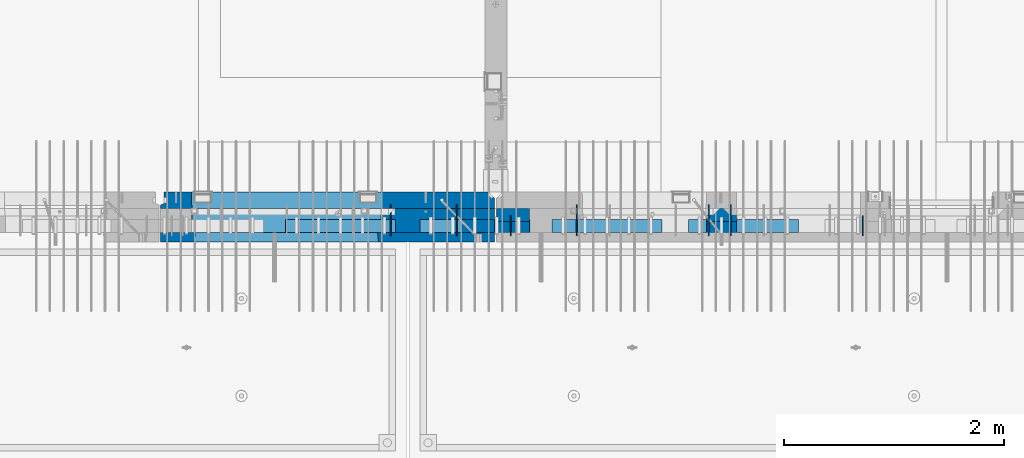
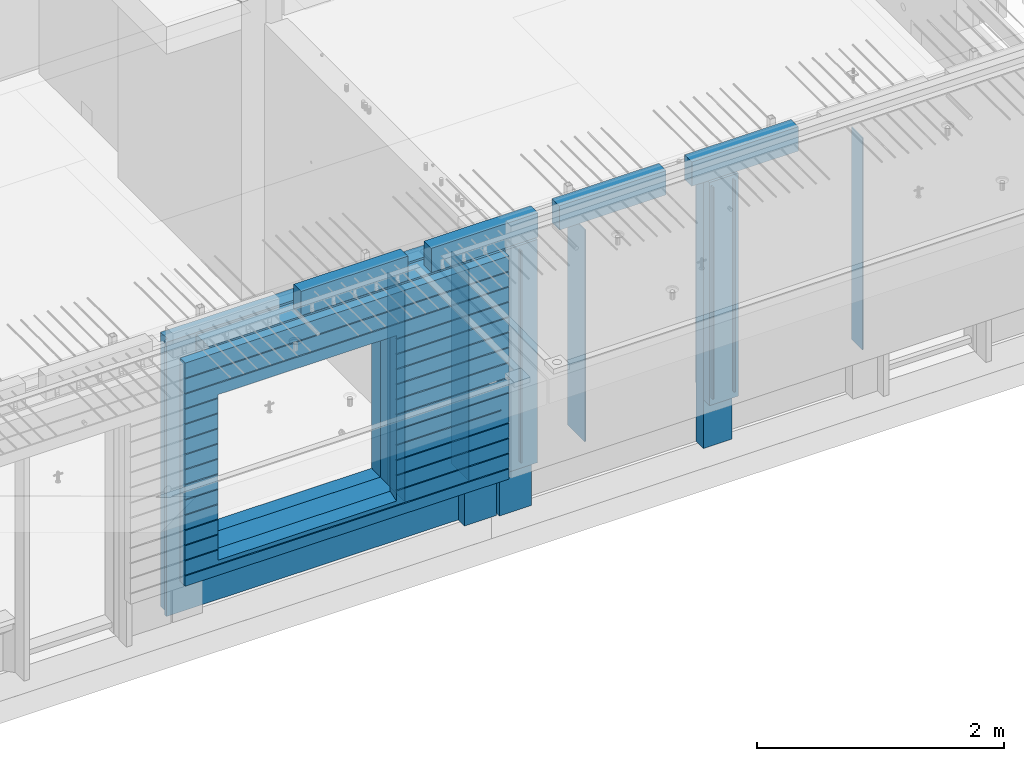
# One storey, part 212 of 325: 20 walls, 8 elements without a shape of their own.
"""IFC2X3 building model written with IfcOpenShell, lengths in millimetres."""

from ifc_helpers import new_model, si_unit, frame, origin_with_axes, place, context, subcontext, project, spatial, faceted_brep, material, type_object, element, aggregate, save


model = new_model("IFC2X3")

# Units and contexts
model_context = context("Model", 3, precision=1e-05, world=origin_with_axes())
body_context = subcontext(model_context, "Body", "Model", "MODEL_VIEW")
ifc_project = project(units=[si_unit("LENGTHUNIT", "METRE", prefix="MILLI"), si_unit("AREAUNIT", "SQUARE_METRE"), si_unit("VOLUMEUNIT", "CUBIC_METRE"), si_unit("MASSUNIT", "GRAM", prefix="KILO"), si_unit("TIMEUNIT", "SECOND"), si_unit("PLANEANGLEUNIT", "RADIAN"), si_unit("SOLIDANGLEUNIT", "STERADIAN"), si_unit("THERMODYNAMICTEMPERATUREUNIT", "DEGREE_CELSIUS"), si_unit("LUMINOUSINTENSITYUNIT", "LUMEN")], contexts=[model_context])

# Site, building, storey
site_placement = place(None, origin_with_axes())
site = spatial("IfcSite", under=ifc_project, at=site_placement, CompositionType="ELEMENT")
building_placement = place(site_placement, origin_with_axes())
building = spatial("IfcBuilding", under=site, at=building_placement, CompositionType="ELEMENT")
storey_placement = place(building_placement, origin_with_axes())
storey = spatial("IfcBuildingStorey", under=building, at=storey_placement, Name="1", CompositionType="ELEMENT", Elevation=0.0)

# Assemblies, wall
assembly_1_placement = place(storey_placement, origin_with_axes())
assembly_1 = element("IfcElementAssembly", 1, at=assembly_1_placement, inside=storey, AssemblyPlace="NOTDEFINED", PredefinedType="REINFORCEMENT_UNIT")
assembly_2_placement = place(assembly_1_placement, origin_with_axes())
assembly_2 = element("IfcElementAssembly", 2, at=assembly_2_placement, Name="Steel Assembly", AssemblyPlace="NOTDEFINED", PredefinedType="NOTDEFINED")
aggregate(assembly_1, [assembly_2])
ifc_material_1 = material()
wall_type_1 = type_object("IfcWallType", PredefinedType="NOTDEFINED")
wall_1_placement = place(assembly_2_placement, frame((26699.9998568133, 7690.00021946163, 84590.0), z_axis=(0.0, 0.0, 1.0), x_axis=(1.0, 0.0, 0.0)))
wall_1 = element("IfcWall", 3, at=wall_1_placement, type_object=wall_type_1, material=ifc_material_1, context=body_context, shape_type="Brep", body=[
    faceted_brep([(0.0, 60.0, -120.0), (0.0, 60.0, 120.0), (1000.0, 60.0, 120.0), (1000.0, 60.0, -120.0), (0.0, -60.0, 120.0), (1000.0, -60.0, 120.0), (0.0, -60.0, -120.0), (1000.0, -60.0, -120.0)], [[[0, 1, 2, 3]], [[1, 4, 5, 2]], [[4, 6, 7, 5]], [[6, 0, 3, 7]], [[5, 7, 3, 2]], [[6, 4, 1, 0]]]),
])
aggregate(assembly_2, [wall_1])

# Assemblies, walls
assembly_3_placement = place(storey_placement, origin_with_axes())
assembly_3 = element("IfcElementAssembly", 4, at=assembly_3_placement, inside=storey, AssemblyPlace="NOTDEFINED", PredefinedType="REINFORCEMENT_UNIT")
assembly_4_placement = place(assembly_3_placement, origin_with_axes())
assembly_4 = element("IfcElementAssembly", 5, at=assembly_4_placement, Name="Steel Assembly", AssemblyPlace="NOTDEFINED", PredefinedType="NOTDEFINED")
wall_2_placement = place(assembly_4_placement, frame((30359.9998568133, 7690.00021946163, 84590.0), z_axis=(0.0, 0.0, 1.0), x_axis=(1.0, 0.0, 0.0)))
wall_2 = element("IfcWall", 6, at=wall_2_placement, type_object=wall_type_1, material=ifc_material_1, context=body_context, shape_type="Brep", body=[
    faceted_brep([(0.0, 60.0, -120.0), (0.0, 60.0, 120.0), (1000.0, 60.0, 120.0), (1000.0, 60.0, -120.0), (0.0, -60.0, 120.0), (1000.0, -60.0, 120.0), (0.0, -60.0, -120.0), (1000.0, -60.0, -120.0)], [[[0, 1, 2, 3]], [[1, 4, 5, 2]], [[4, 6, 7, 5]], [[6, 0, 3, 7]], [[5, 7, 3, 2]], [[6, 4, 1, 0]]]),
])
aggregate(assembly_4, [wall_2])
assembly_5_placement = place(assembly_3_placement, origin_with_axes())
assembly_5 = element("IfcElementAssembly", 7, at=assembly_5_placement, Name="Steel Assembly", AssemblyPlace="NOTDEFINED", PredefinedType="NOTDEFINED")
wall_3_placement = place(assembly_5_placement, frame((29119.9998568133, 7690.00021946163, 84590.0), z_axis=(0.0, 0.0, 1.0), x_axis=(1.0, 0.0, 0.0)))
wall_3 = element("IfcWall", 8, at=wall_3_placement, type_object=wall_type_1, material=ifc_material_1, context=body_context, shape_type="Brep", body=[
    faceted_brep([(0.0, 60.0, -120.0), (0.0, 60.0, 120.0), (1000.0, 60.0, 120.0), (1000.0, 60.0, -120.0), (0.0, -60.0, 120.0), (1000.0, -60.0, 120.0), (0.0, -60.0, -120.0), (1000.0, -60.0, -120.0)], [[[0, 1, 2, 3]], [[1, 4, 5, 2]], [[4, 6, 7, 5]], [[6, 0, 3, 7]], [[5, 7, 3, 2]], [[6, 4, 1, 0]]]),
])
aggregate(assembly_5, [wall_3])
assembly_6_placement = place(assembly_3_placement, origin_with_axes())
assembly_6 = element("IfcElementAssembly", 9, at=assembly_6_placement, Name="Steel Assembly", AssemblyPlace="NOTDEFINED", PredefinedType="NOTDEFINED")
aggregate(assembly_3, [assembly_6, assembly_5, assembly_4])
wall_4_placement = place(assembly_6_placement, frame((27919.9998568133, 7690.00021946163, 84590.0), z_axis=(0.0, 0.0, 1.0), x_axis=(1.0, 0.0, 0.0)))
wall_4 = element("IfcWall", 10, at=wall_4_placement, type_object=wall_type_1, material=ifc_material_1, context=body_context, shape_type="Brep", body=[
    faceted_brep([(0.0, 60.0, -120.0), (0.0, 60.0, 120.0), (1000.0, 60.0, 120.0), (1000.0, 60.0, -120.0), (0.0, -60.0, 120.0), (1000.0, -60.0, 120.0), (0.0, -60.0, -120.0), (1000.0, -60.0, -120.0)], [[[0, 1, 2, 3]], [[1, 4, 5, 2]], [[4, 6, 7, 5]], [[6, 0, 3, 7]], [[5, 7, 3, 2]], [[6, 4, 1, 0]]]),
])
aggregate(assembly_6, [wall_4])

# Assembly, walls
assembly_7_placement = place(storey_placement, origin_with_axes())
assembly_7 = element("IfcElementAssembly", 11, at=assembly_7_placement, inside=storey, AssemblyPlace="NOTDEFINED", PredefinedType="REINFORCEMENT_UNIT")
ifc_material_2 = material(Name="CONCRETE/C35/45")
wall_type_2 = type_object("IfcWallType", PredefinedType="NOTDEFINED")
wall_5_placement = place(assembly_7_placement, frame((28600.0, 7925.0, 83112.5), z_axis=(0.0, 0.0, 1.0), x_axis=(-1.0, 3.00000001838171e-08, 0.0)))
wall_5 = element("IfcWall", 12, at=wall_5_placement, type_object=wall_type_2, material=ifc_material_2, context=body_context, shape_type="Brep", body=[
    faceted_brep([(0.0, 75.0, 1357.5), (0.0, 75.0, -1357.5), (0.0, -15.0, -1357.5), (0.0, -15.0, 1357.5), (60.0, -75.0, -1357.5), (3035.00000000003, 75.0, -1357.5), (3035.00000000003, 45.0, -1357.5), (3002.5, 32.0, -1357.5), (3002.5, -75.0, -1357.5), (60.0, -75.0, 1357.5), (3035.00000000003, 45.0, 1357.5), (3035.00000000003, 75.0, 1357.5), (3002.5, -75.0, 1357.5), (3002.5, 32.0, 1357.5), (2755.00051719707, -75.0, -682.5), (1025.00051719707, -75.0, -682.5), (1025.00051719707, -75.0, 952.5), (2755.00051719707, -75.0, 952.5), (2750.94646314301, 75.0, -678.445945945947), (1029.05457125112, 75.0, -678.445945945947), (1029.05457125112, 75.0, 948.445945945947), (2750.94646314301, 75.0, 948.445945945947)], [[[0, 1, 2, 3]], [[4, 2, 1, 5, 6, 7, 8]], [[3, 2, 4, 9]], [[10, 11, 0, 3, 9, 12, 13]], [[5, 11, 10, 6]], [[13, 7, 6, 10]], [[12, 8, 7, 13]], [[9, 4, 8, 12], [14, 15, 16, 17]], [[14, 18, 19, 15]], [[15, 19, 20, 16]], [[1, 0, 11, 5], [18, 21, 20, 19]], [[16, 20, 21, 17]], [[18, 14, 17, 21]]]),
])
ifc_material_3 = material(Name="Undefined")
wall_type_3 = type_object("IfcWallType", PredefinedType="NOTDEFINED")
wall_6_placement = place(assembly_7_placement, frame((28255.0, 7880.0, 83365.0), z_axis=(0.0, 0.0, 1.0), x_axis=(0.0, -1.0, 0.0)))
wall_6 = element("IfcWall", 13, at=wall_6_placement, type_object=wall_type_3, material=ifc_material_3, Name="(PD)", context=body_context, shape_type="Brep", body=[
    faceted_brep([(0.0, 5.0, -1050.0), (0.0, 5.0, 1050.0), (280.0, 5.0, 1050.0), (280.0, 5.0, -1050.0), (0.0, -5.0, 1050.0), (280.0, -5.0, 1050.0), (0.0, -5.0, -1050.0), (280.0, -5.0, -1050.0)], [[[0, 1, 2, 3]], [[1, 4, 5, 2]], [[4, 6, 7, 5]], [[6, 0, 3, 7]], [[5, 7, 3, 2]], [[6, 4, 1, 0]]]),
])

assembly_8_placement = place(storey_placement, origin_with_axes())
assembly_8 = element("IfcElementAssembly", 14, at=assembly_8_placement, inside=storey, AssemblyPlace="NOTDEFINED", PredefinedType="REINFORCEMENT_UNIT")
wall_7_placement = place(assembly_8_placement, frame((31944.9998946285, 7780.0, 83365.0), z_axis=(0.0, 0.0, 1.0), x_axis=(0.0, -1.0, 0.0)))
wall_7 = element("IfcWall", 15, at=wall_7_placement, type_object=wall_type_3, material=ifc_material_3, Name="(PD)", context=body_context, shape_type="Brep", body=[
    faceted_brep([(0.0, 5.0, -1050.0), (0.0, 5.0, 1050.0), (180.0, 5.0, 1050.0), (180.0, 5.0, -1050.0), (0.0, -5.0, 1050.0), (180.0, -5.0, 1050.0), (0.0, -5.0, -1050.0), (180.0, -5.0, -1050.0)], [[[0, 1, 2, 3]], [[1, 4, 5, 2]], [[4, 6, 7, 5]], [[6, 0, 3, 7]], [[5, 7, 3, 2]], [[6, 4, 1, 0]]]),
])
wall_8_placement = place(assembly_8_placement, frame((28745.0021834468, 7780.0, 83365.0), z_axis=(0.0, 0.0, 1.0), x_axis=(0.0, -1.0, 0.0)))
wall_8 = element("IfcWall", 16, at=wall_8_placement, type_object=wall_type_3, material=ifc_material_3, Name="(PD)", context=body_context, shape_type="Brep", body=[
    faceted_brep([(0.0, 5.0, -1050.0), (0.0, 5.0, 1050.0), (180.0, 5.0, 1050.0), (180.0, 5.0, -1050.0), (0.0, -5.0, 1050.0), (180.0, -5.0, 1050.0), (0.0, -5.0, -1050.0), (180.0, -5.0, -1050.0)], [[[0, 1, 2, 3]], [[1, 4, 5, 2]], [[4, 6, 7, 5]], [[6, 0, 3, 7]], [[5, 7, 3, 2]], [[6, 4, 1, 0]]]),
])
wall_9_placement = place(assembly_8_placement, frame((29345.0021834468, 7880.0, 83365.0), z_axis=(0.0, 0.0, 1.0), x_axis=(0.0, -1.0, 0.0)))
wall_9 = element("IfcWall", 17, at=wall_9_placement, type_object=wall_type_3, material=ifc_material_3, Name="(PD)", context=body_context, shape_type="Brep", body=[
    faceted_brep([(0.0, 5.0, -1050.0), (0.0, 5.0, 1050.0), (280.0, 5.0, 1050.0), (280.0, 5.0, -1050.0), (0.0, -5.0, 1050.0), (280.0, -5.0, 1050.0), (0.0, -5.0, -1050.0), (280.0, -5.0, -1050.0)], [[[0, 1, 2, 3]], [[1, 4, 5, 2]], [[4, 6, 7, 5]], [[6, 0, 3, 7]], [[5, 7, 3, 2]], [[6, 4, 1, 0]]]),
])
wall_10_placement = place(assembly_8_placement, frame((30545.0021834468, 7880.0, 83365.0), z_axis=(0.0, 0.0, 1.0), x_axis=(0.0, -1.0, 0.0)))
wall_10 = element("IfcWall", 18, at=wall_10_placement, type_object=wall_type_3, material=ifc_material_3, Name="(PD)", context=body_context, shape_type="Brep", body=[
    faceted_brep([(0.0, 5.0, -1050.0), (0.0, 5.0, 1050.0), (280.0, 5.0, 1050.0), (280.0, 5.0, -1050.0), (0.0, -5.0, 1050.0), (280.0, -5.0, 1050.0), (0.0, -5.0, -1050.0), (280.0, -5.0, -1050.0)], [[[0, 1, 2, 3]], [[1, 4, 5, 2]], [[4, 6, 7, 5]], [[6, 0, 3, 7]], [[5, 7, 3, 2]], [[6, 4, 1, 0]]]),
])
wall_11_placement = place(assembly_8_placement, frame((30745.0021834468, 7880.0, 83365.0), z_axis=(0.0, 0.0, 1.0), x_axis=(0.0, -1.0, 0.0)))
wall_11 = element("IfcWall", 19, at=wall_11_placement, type_object=wall_type_3, material=ifc_material_3, Name="(PD)", context=body_context, shape_type="Brep", body=[
    faceted_brep([(0.0, 5.0, -1050.0), (0.0, 5.0, 1050.0), (280.0, 5.0, 1050.0), (280.0, 5.0, -1050.0), (0.0, -5.0, 1050.0), (280.0, -5.0, 1050.0), (0.0, -5.0, -1050.0), (280.0, -5.0, -1050.0)], [[[0, 1, 2, 3]], [[1, 4, 5, 2]], [[4, 6, 7, 5]], [[6, 0, 3, 7]], [[5, 7, 3, 2]], [[6, 4, 1, 0]]]),
])

# Wall
wall_12_placement = place(assembly_7_placement, frame((27655.0, 7880.0, 83365.0), z_axis=(0.0, 0.0, 1.0), x_axis=(0.0, -1.0, 0.0)))
wall_12 = element("IfcWall", 20, at=wall_12_placement, type_object=wall_type_3, material=ifc_material_3, Name="(PD)", context=body_context, shape_type="Brep", body=[
    faceted_brep([(0.0, 5.0, -1050.0), (0.0, 5.0, 1050.0), (280.0, 5.0, 1050.0), (280.0, 5.0, -1050.0), (0.0, -5.0, 1050.0), (280.0, -5.0, 1050.0), (0.0, -5.0, -1050.0), (280.0, -5.0, -1050.0)], [[[0, 1, 2, 3]], [[1, 4, 5, 2]], [[4, 6, 7, 5]], [[6, 0, 3, 7]], [[5, 7, 3, 2]], [[6, 4, 1, 0]]]),
])

wall_type_4 = type_object("IfcWallType", PredefinedType="NOTDEFINED")
wall_13_placement = place(assembly_7_placement, frame((28600.0000381475, 7800.0, 83112.5), z_axis=(0.0, 0.0, 1.0), x_axis=(-1.0, 3.00000001838171e-08, 0.0)))
wall_13 = element("IfcWall", 21, at=wall_13_placement, type_object=wall_type_4, material=ifc_material_2, context=body_context, shape_type="Brep", body=[
    faceted_brep([(0.0, 50.0, -1357.5), (0.0, 50.0, 1357.5), (300.001908754726, 50.0, 1357.5), (300.001908754726, 50.0, -1357.5), (0.0, -50.0, 1357.5), (300.001908754726, -50.0, 1357.5), (0.0, -50.0, -1357.5), (300.001908754726, -50.0, -1357.5)], [[[0, 1, 2, 3]], [[1, 4, 5, 2]], [[4, 6, 7, 5]], [[6, 0, 3, 7]], [[5, 7, 3, 2]], [[6, 4, 1, 0]]]),
])

ifc_material_4 = material(Name="SPU")
wall_type_5 = type_object("IfcWallType", PredefinedType="NOTDEFINED")
wall_14_placement = place(assembly_7_placement, frame((28600.0000381475, 7690.0, 83102.5), z_axis=(0.0, 0.0, 1.0), x_axis=(-1.0, 3.00000001838171e-08, 0.0)))
wall_14 = element("IfcWall", 22, at=wall_14_placement, type_object=wall_type_5, material=ifc_material_4, context=body_context, shape_type="Brep", body=[
    faceted_brep([(0.0, 60.0, 1347.5), (0.0, -60.0, 1347.5), (300.001908754726, -60.0, 1347.5), (300.001908754726, 60.0, 1347.5), (0.0, -60.0, -862.5), (300.001908754726, -60.0, -862.5), (300.001908754726, 60.0, -862.5), (0.0, 60.0, -862.5)], [[[0, 1, 2, 3]], [[2, 1, 4, 5]], [[3, 2, 5, 6]], [[0, 3, 6, 7]], [[1, 0, 7, 4]], [[6, 5, 4, 7]]]),
])

wall_type_6 = type_object("IfcWallType", PredefinedType="NOTDEFINED")
wall_15_placement = place(assembly_8_placement, frame((30795.0000381475, 7680.0, 83102.5), z_axis=(0.0, 0.0, 1.0), x_axis=(-1.0, 3.00000001838171e-08, 0.0)))
wall_15 = element("IfcWall", 23, at=wall_15_placement, type_object=wall_type_6, material=ifc_material_4, context=body_context, shape_type="Brep", body=[
    faceted_brep([(0.0, 50.0, 1347.5), (0.0, -50.0, 1347.5), (270.001908754726, -50.0, 1347.5), (270.001908754726, 50.0, 1347.5), (0.0, -50.0, -862.5), (270.001908754726, -50.0, -862.5), (270.001908754726, 50.0, -862.5), (0.0, 50.0, -862.5)], [[[0, 1, 2, 3]], [[2, 1, 4, 5]], [[3, 2, 5, 6]], [[0, 3, 6, 7]], [[1, 0, 7, 4]], [[6, 5, 4, 7]]]),
])

wall_16_placement = place(assembly_8_placement, frame((28915.0000381475, 7680.0, 83102.5), z_axis=(0.0, 0.0, 1.0), x_axis=(-1.0, 3.00000001838171e-08, 0.0)))
wall_16 = element("IfcWall", 24, at=wall_16_placement, type_object=wall_type_6, material=ifc_material_4, context=body_context, shape_type="Brep", body=[
    faceted_brep([(0.0, 50.0, 1347.5), (0.0, -50.0, 1347.5), (300.001908754726, -50.0, 1347.5), (300.001908754726, 50.0, 1347.5), (0.0, -50.0, -862.5), (300.001908754726, -50.0, -862.5), (300.001908754726, 50.0, -862.5), (0.0, 50.0, -862.5)], [[[0, 1, 2, 3]], [[2, 1, 4, 5]], [[3, 2, 5, 6]], [[0, 3, 6, 7]], [[1, 0, 7, 4]], [[6, 5, 4, 7]]]),
])

wall_type_7 = type_object("IfcWallType", PredefinedType="NOTDEFINED")
wall_17_placement = place(assembly_8_placement, frame((30795.0000381475, 7790.0, 83112.5), z_axis=(0.0, 0.0, 1.0), x_axis=(-1.0, 3.00000001838171e-08, 0.0)))
wall_17 = element("IfcWall", 25, at=wall_17_placement, type_object=wall_type_7, material=ifc_material_2, context=body_context, shape_type="Brep", body=[
    faceted_brep([(0.0, 60.0, -1357.5), (0.0, 60.0, 1357.5), (270.001908754726, 60.0, 1357.5), (270.001908754726, 60.0, -1357.5), (0.0, -60.0, 1357.5), (270.001908754726, -60.0, 1357.5), (0.0, -60.0, -1357.5), (270.001908754726, -60.0, -1357.5)], [[[0, 1, 2, 3]], [[1, 4, 5, 2]], [[4, 6, 7, 5]], [[6, 0, 3, 7]], [[5, 7, 3, 2]], [[6, 4, 1, 0]]]),
])

wall_18_placement = place(assembly_8_placement, frame((28915.0000381475, 7790.0, 83112.5), z_axis=(0.0, 0.0, 1.0), x_axis=(-1.0, 3.00000001838171e-08, 0.0)))
wall_18 = element("IfcWall", 26, at=wall_18_placement, type_object=wall_type_7, material=ifc_material_2, context=body_context, shape_type="Brep", body=[
    faceted_brep([(0.0, 60.0, -1357.5), (0.0, 60.0, 1357.5), (300.001908754726, 60.0, 1357.5), (300.001908754726, 60.0, -1357.5), (0.0, -60.0, 1357.5), (300.001908754726, -60.0, 1357.5), (0.0, -60.0, -1357.5), (300.001908754726, -60.0, -1357.5)], [[[0, 1, 2, 3]], [[1, 4, 5, 2]], [[4, 6, 7, 5]], [[6, 0, 3, 7]], [[5, 7, 3, 2]], [[6, 4, 1, 0]]]),
])

aggregate(assembly_8, [wall_15, wall_17, wall_16, wall_18, wall_7, wall_8, wall_9, wall_10, wall_11])

ifc_material_5 = material(Name="CONCRETE/C30/37")
wall_type_8 = type_object("IfcWallType", PredefinedType="NOTDEFINED")
wall_19_placement = place(assembly_7_placement, frame((28600.0, 7587.5, 83102.5), z_axis=(0.0, 0.0, 1.0), x_axis=(-1.0, 3.00000001838171e-08, 0.0)))
wall_19 = element("IfcWall", 27, at=wall_19_placement, type_object=wall_type_8, material=ifc_material_5, context=body_context, shape_type="Brep", body=[
    faceted_brep([(0.0, 42.5, 1347.5), (0.0, -42.5, 1347.5), (3035.0, -42.5, 1347.5), (3035.0, 42.5, 1347.5), (3035.0, 42.5, 1201.99999988925), (0.0, 42.5, 1201.99999988925), (3035.0, 32.4999991119703, 1200.00000040044), (-3.63797880709171e-12, 32.4999991119576, 1200.00000040043), (3035.0, 32.4999992499634, 1189.99999999921), (-3.63797880709171e-12, 32.499999249967, 1189.99999999923), (3035.0, 42.5, 1187.99999994476), (0.0, 42.5, 1187.99999994476), (3035.0, 42.5, 1051.99999988925), (0.0, 42.5, 1051.99999988925), (3035.0, 32.4999991119785, 1050.00000040044), (3.63797880709171e-12, 32.4999991119639, 1050.00000040043), (3035.0, 32.4999992499725, 1039.99999999921), (3.63797880709171e-12, 32.4999992499725, 1039.99999999921), (3035.0, 42.5, 1037.99999994476), (0.0, 42.5, 1037.99999994476), (3035.0, 42.5, 901.999999889245), (3035.0, 32.4999991119894, 900.00000040044), (2723.82404650436, 32.4999991119894, 900.00000040044), (2725.00051719707, 42.5, 901.999999889245), (3035.0, 32.4999992499834, 889.999999999214), (2723.82404652059, 32.4999992499834, 889.999999999214), (3035.0, 42.5, 887.999999944761), (2725.00051719707, 42.5, 887.999999944761), (3035.0, 42.5, 751.999999889245), (2725.00051719707, 42.5, 751.999999889245), (3035.0, 32.4999991119967, 750.000000400425), (2723.82404650436, 32.4999991119967, 750.000000400425), (3035.0, 32.4999992499961, 739.9999999992), (2723.82404652059, 32.4999992499961, 739.9999999992), (3035.0, 42.5, 737.999999944761), (2725.00051719707, 42.5, 737.999999944761), (3035.0, 42.5, 601.99999988926), (2725.00051719707, 42.5, 601.99999988926), (3035.0, 32.4999991120212, 600.000000400454), (2723.82404650436, 32.4999991120212, 600.000000400454), (3035.0, 32.4999992500161, 589.999999999229), (2723.8240465206, 32.4999992500161, 589.999999999229), (3035.0, 42.5, 587.999999944775), (2725.00051719707, 42.5, 587.999999944775), (3035.0, 42.5, 451.999999889231), (2725.00051719707, 42.5, 451.999999889231), (3035.0, 32.4999991120285, 450.000000400425), (2723.82404650436, 32.4999991120285, 450.000000400425), (3035.0, 32.4999992500234, 439.9999999992), (2723.8240465206, 32.4999992500234, 439.9999999992), (3035.0, 42.5, 437.999999944746), (2725.00051719707, 42.5, 437.999999944746), (3035.0, 42.5, 301.999999889245), (2725.00051719707, 42.5, 301.999999889245), (3035.0, 32.4999991120458, 300.00000040044), (2723.82404650437, 32.4999991120458, 300.00000040044), (3035.0, 32.4999992500389, 289.999999999214), (2723.8240465206, 32.4999992500389, 289.999999999214), (3035.0, 42.5, 287.999999944761), (2725.00051719707, 42.5, 287.999999944761), (3035.0, 42.5, 151.99999988926), (2725.00051719707, 42.5, 151.99999988926), (3035.0, 32.4999991120585, 150.000000400454), (2723.82404650437, 32.4999991120585, 150.000000400454), (3035.0, 32.4999992500534, 139.999999999229), (2723.8240465206, 32.4999992500534, 139.999999999229), (3035.0, 42.5, 137.999999944775), (2725.00051719707, 42.5, 137.999999944775), (3035.0, 42.5, 1.99999988924537), (2725.00051719707, 42.5, 1.99999988924537), (3035.0, 32.4999991158902, 4.00425051338971e-07), (2723.82404650482, 32.4999991158902, 4.00425051338971e-07), (3035.0, 32.4999992538906, -10.0000000008004), (2723.82404652105, 32.4999992538906, -10.0000000008004), (3035.0, 42.5, -12.0000000552391), (2725.00051719707, 42.5, -12.0000000552391), (3035.0, 42.5, -148.000000110755), (2725.00051719707, 42.4999999210722, -148.000000110755), (3035.0, 32.4999991158938, -149.999999599575), (2723.82404650482, 32.4999991158938, -149.999999599575), (3035.0, 32.4999992538951, -160.0000000008), (2723.82404652105, 32.4999992538951, -160.0000000008), (3035.0, 42.5, -162.000000055239), (2725.00051719707, 42.499999923677, -162.000000055239), (3035.0, 42.5, -298.000000110769), (2725.00051719707, 42.5, -298.000000110769), (3035.0, 32.4999991153563, -299.99999959959), (2723.82404650475, 32.4999991153563, -299.99999959959), (3035.0, 32.4999992533585, -310.000000000815), (2723.82404652099, 32.4999992533585, -310.000000000815), (3035.0, 42.5, -312.000000055254), (2725.00051719707, 42.5, -312.000000055254), (3035.0, 42.5, -448.000000110755), (2725.00051719707, 42.5, -448.000000110755), (3035.0, 32.4999991148297, -449.999999599575), (2723.82404650469, 32.4999991148297, -449.999999599575), (3035.0, 32.4999992528319, -460.0000000008), (2723.82404652093, 32.4999992528319, -460.0000000008), (3035.0, 42.5, -462.000000055239), (2725.00051719707, 42.5, -462.000000055239), (3035.0, 42.5, -598.000000110755), (2725.00051719707, 42.5, -598.000000110755), (3035.0, 32.4999991142904, -599.999999599575), (2723.82404650463, 32.4999991142904, -599.999999599575), (3035.0, 32.4999992522926, -610.0000000008), (2723.82404652087, 32.4999992522926, -610.0000000008), (3035.0, 42.5, -612.000000055239), (2725.00051719707, 42.5, -612.000000055239), (0.0, 32.4999992517696, -760.000000000757), (3035.0, 32.499999251766, -760.000000000786), (3035.0, 42.5, -762.000000055225), (0.0, 42.5, -762.000000055225), (0.0, 32.4999991137702, -749.99999959956), (3035.0, 32.4999991137656, -749.99999959956), (0.0, 42.5, -748.00000011074), (3035.0, 42.5, -748.00000011074), (75.0, 42.4999992463618, -148.000000110755), (75.0, 32.4999991158938, -149.999999599575), (75.0, 32.4999992538951, -160.0000000008), (75.0, 42.4999992712401, -162.000000055239), (1055.00051719707, 42.4999994958771, -148.000000110755), (1056.17698788932, 32.4999991158938, -149.999999599575), (1056.17698787308, 32.4999992538951, -160.0000000008), (1055.00051719707, 42.499999512519, -162.000000055239), (3.63797880709171e-12, 32.4999992499852, 889.999999999229), (3.63797880709171e-12, 32.4999991119857, 900.000000400425), (1056.17698788978, 32.4999991119894, 900.00000040044), (1056.17698787354, 32.4999992499834, 889.999999999214), (0.0, 42.5, 887.999999944761), (1055.00051719707, 42.5, 887.999999944761), (0.0, 42.5, 751.999999889245), (1055.00051719707, 42.5, 751.999999889245), (0.0, 32.4999991120039, 750.00000040044), (1056.17698788978, 32.4999991119967, 750.000000400425), (0.0, 32.4999992499997, 739.999999999229), (1056.17698787354, 32.4999992499961, 739.9999999992), (0.0, 42.5, 737.999999944761), (1055.00051719707, 42.5, 737.999999944761), (0.0, 42.5, 601.99999988926), (1055.00051719707, 42.5, 601.99999988926), (0.0, 32.4999991120094, 600.00000040044), (1056.17698788977, 32.4999991120212, 600.000000400454), (0.0, 32.499999250017, 589.999999999229), (1056.17698787354, 32.4999992500161, 589.999999999229), (0.0, 42.5, 587.999999944775), (1055.00051719707, 42.5, 587.999999944775), (0.0, 42.5, 451.999999889231), (1055.00051719707, 42.5, 451.999999889231), (0.0, 32.4999991120258, 450.000000400411), (1056.17698788977, 32.4999991120285, 450.000000400425), (0.0, 32.4999992500289, 439.999999999214), (1056.17698787354, 32.4999992500234, 439.9999999992), (0.0, 42.5, 437.999999944746), (1055.00051719707, 42.5, 437.999999944746), (0.0, 42.5, 301.999999889245), (1055.00051719707, 42.5, 301.999999889245), (-3.63797880709171e-12, 32.4999991120458, 300.00000040044), (1056.17698788977, 32.4999991120458, 300.00000040044), (-3.63797880709171e-12, 32.4999992500416, 289.999999999229), (1056.17698787353, 32.4999992500389, 289.999999999214), (0.0, 42.5, 287.999999944761), (1055.00051719707, 42.5, 287.999999944761), (0.0, 42.5, 151.99999988926), (1055.00051719707, 42.5, 151.99999988926), (0.0, 32.4999991120549, 150.00000040044), (1056.17698788977, 32.4999991120585, 150.000000400454), (0.0, 32.4999992500552, 139.999999999229), (1056.17698787353, 32.4999992500534, 139.999999999229), (0.0, 42.5, 137.999999944775), (1055.00051719707, 42.5, 137.999999944775), (0.0, 42.5, 1.99999988924537), (1055.00051719707, 42.5, 1.99999988924537), (0.0, 32.4999991158911, 4.00425051338971e-07), (1056.17698788932, 32.4999991158902, 4.00425051338971e-07), (0.0, 32.4999992538942, -10.0000000007858), (1056.17698787308, 32.4999992538906, -10.0000000008004), (0.0, 42.5, -12.0000000552391), (1055.00051719707, 42.5, -12.0000000552391), (1055.00051719707, 42.5, -298.000000110769), (0.0, 42.5, -298.000000110769), (0.0, 32.4999991153618, -299.99999959959), (1056.17698788938, 32.4999991153563, -299.99999959959), (0.0, 32.4999992533649, -310.000000000786), (1056.17698787315, 32.4999992533585, -310.000000000815), (0.0, 42.5, -312.000000055254), (1055.00051719707, 42.5, -312.000000055254), (0.0, 42.5, -448.000000110755), (1055.00051719707, 42.5, -448.000000110755), (0.0, 32.4999991148252, -449.999999599575), (1056.17698788944, 32.4999991148297, -449.999999599575), (0.0, 32.4999992528365, -460.000000000771), (1056.17698787321, 32.4999992528319, -460.0000000008), (0.0, 42.5, -462.000000055239), (1055.00051719707, 42.5, -462.000000055239), (0.0, 42.5, -598.000000110755), (1055.00051719707, 42.5, -598.000000110755), (0.0, 32.4999991143004, -599.99999959956), (1056.1769878895, 32.4999991142904, -599.999999599575), (0.0, 32.4999992522971, -610.000000000771), (1056.17698787327, 32.4999992522926, -610.0000000008), (0.0, 42.5, -612.000000055239), (1055.00051719707, 42.5, -612.000000055239), (2725.00051719707, 42.5, -712.5), (1055.00051719707, 42.5, -712.5), (1065.00051719707, -42.5, -662.5), (2715.00051719707, -42.5, -662.5), (2715.00051719707, -42.5, 927.5), (2715.00051719707, -42.5, 932.5), (2725.00051719707, 42.5, 927.5), (0.0, 42.5, 901.999999889245), (2715.00051719707, 42.5, 927.5), (1065.00051719707, 42.5, 927.5), (1055.00051719707, 42.5, 927.5), (1055.00051719707, 42.5, 901.999999889245), (1065.00051719707, -42.5, 932.5), (1065.00051719707, -42.5, 927.5), (0.0, -42.5, -862.5), (3035.0, -42.5, -862.5), (3035.0, 42.5, -862.5), (0.0, 42.5, -862.5)], [[[0, 1, 2, 3]], [[0, 3, 4, 5]], [[5, 4, 6, 7]], [[7, 6, 8, 9]], [[9, 8, 10, 11]], [[12, 13, 11, 10]], [[13, 12, 14, 15]], [[15, 14, 16, 17]], [[17, 16, 18, 19]], [[20, 21, 22, 23]], [[21, 24, 25, 22]], [[24, 26, 27, 25]], [[26, 28, 29, 27]], [[28, 30, 31, 29]], [[30, 32, 33, 31]], [[32, 34, 35, 33]], [[34, 36, 37, 35]], [[36, 38, 39, 37]], [[38, 40, 41, 39]], [[40, 42, 43, 41]], [[42, 44, 45, 43]], [[44, 46, 47, 45]], [[46, 48, 49, 47]], [[48, 50, 51, 49]], [[50, 52, 53, 51]], [[52, 54, 55, 53]], [[54, 56, 57, 55]], [[56, 58, 59, 57]], [[58, 60, 61, 59]], [[60, 62, 63, 61]], [[62, 64, 65, 63]], [[64, 66, 67, 65]], [[66, 68, 69, 67]], [[68, 70, 71, 69]], [[70, 72, 73, 71]], [[72, 74, 75, 73]], [[74, 76, 77, 75]], [[76, 78, 79, 77]], [[78, 80, 81, 79]], [[80, 82, 83, 81]], [[82, 84, 85, 83]], [[84, 86, 87, 85]], [[86, 88, 89, 87]], [[88, 90, 91, 89]], [[90, 92, 93, 91]], [[92, 94, 95, 93]], [[94, 96, 97, 95]], [[96, 98, 99, 97]], [[98, 100, 101, 99]], [[100, 102, 103, 101]], [[102, 104, 105, 103]], [[104, 106, 107, 105]], [[108, 109, 110, 111]], [[112, 113, 109, 108]], [[114, 115, 113, 112]], [[116, 117, 118, 119]], [[117, 116, 120, 121]], [[118, 117, 121, 122]], [[119, 118, 122, 123]], [[124, 125, 126, 127]], [[128, 124, 127, 129]], [[130, 128, 129, 131]], [[132, 130, 131, 133]], [[134, 132, 133, 135]], [[136, 134, 135, 137]], [[138, 136, 137, 139]], [[140, 138, 139, 141]], [[142, 140, 141, 143]], [[144, 142, 143, 145]], [[146, 144, 145, 147]], [[148, 146, 147, 149]], [[150, 148, 149, 151]], [[152, 150, 151, 153]], [[154, 152, 153, 155]], [[156, 154, 155, 157]], [[158, 156, 157, 159]], [[160, 158, 159, 161]], [[162, 160, 161, 163]], [[164, 162, 163, 165]], [[166, 164, 165, 167]], [[168, 166, 167, 169]], [[170, 168, 169, 171]], [[172, 170, 171, 173]], [[174, 172, 173, 175]], [[176, 174, 175, 177]], [[116, 119, 123, 178, 179, 176, 177, 120]], [[180, 179, 178, 181]], [[182, 180, 181, 183]], [[184, 182, 183, 185]], [[186, 184, 185, 187]], [[188, 186, 187, 189]], [[190, 188, 189, 191]], [[192, 190, 191, 193]], [[194, 192, 193, 195]], [[196, 194, 195, 197]], [[198, 196, 197, 199]], [[200, 198, 199, 201]], [[202, 107, 106, 115, 114, 200, 201, 203]], [[203, 204, 205, 202]], [[206, 207, 208, 23, 22, 25, 27, 29, 31, 33, 35, 37, 39, 41, 43, 45, 47, 49, 51, 53, 55, 57, 59, 61, 63, 65, 67, 69, 71, 73, 75, 77, 79, 81, 83, 85, 87, 89, 91, 93, 95, 97, 99, 101, 103, 105, 107, 202, 205]], [[209, 19, 18, 20, 23, 208, 210, 211, 212, 213]], [[125, 209, 213, 126]], [[212, 214, 215, 204, 203, 201, 199, 197, 195, 193, 191, 189, 187, 185, 183, 181, 178, 123, 122, 121, 120, 177, 175, 173, 171, 169, 167, 165, 163, 161, 159, 157, 155, 153, 151, 149, 147, 145, 143, 141, 139, 137, 135, 133, 131, 129, 127, 126, 213]], [[211, 210, 208, 207, 214, 212]], [[2, 1, 216, 217], [206, 205, 204, 215, 214, 207]], [[110, 109, 113, 115, 106, 104, 102, 100, 98, 96, 94, 92, 90, 88, 86, 84, 82, 80, 78, 76, 74, 72, 70, 68, 66, 64, 62, 60, 58, 56, 54, 52, 50, 48, 46, 44, 42, 40, 38, 36, 34, 32, 30, 28, 26, 24, 21, 20, 18, 16, 14, 12, 10, 8, 6, 4, 3, 2, 217, 218]], [[111, 110, 218, 219]], [[1, 0, 5, 7, 9, 11, 13, 15, 17, 19, 209, 125, 124, 128, 130, 132, 134, 136, 138, 140, 142, 144, 146, 148, 150, 152, 154, 156, 158, 160, 162, 164, 166, 168, 170, 172, 174, 176, 179, 180, 182, 184, 186, 188, 190, 192, 194, 196, 198, 200, 114, 112, 108, 111, 219, 216]], [[218, 217, 216, 219]]]),
])

ifc_material_6 = material(Name="COS5gt")
wall_type_9 = type_object("IfcWallType", PredefinedType="NOTDEFINED")
wall_20_placement = place(assembly_7_placement, frame((28600.0, 7740.0, 83102.5), z_axis=(0.0, 0.0, 1.0), x_axis=(-1.0, 3.00000001838171e-08, 0.0)))
wall_20 = element("IfcWall", 28, at=wall_20_placement, type_object=wall_type_9, material=ifc_material_6, context=body_context, shape_type="Brep", body=[
    faceted_brep([(300.001870607201, 90.0, -812.5), (2754.99996185248, 90.0, -812.5), (2755.0, 90.0, -862.5), (300.001870607201, 90.0, -862.5), (300.001870607201, 110.0, -812.5), (2755.0, 110.0, -812.5), (2755.0, -110.0, -862.5), (300.001870607201, -110.0, -862.5), (2755.0, 110.0, 1297.5), (2754.99996185248, 90.0, 1297.5), (2755.0, 90.0, 1347.5), (2755.0, -110.0, 1347.5), (300.001870607201, 90.0, 1297.5), (300.001870607201, 110.0, 1297.5), (300.001870607201, 90.0, 1347.5), (300.001870607201, -110.0, 1347.5), (2750.94646314301, -110.0, -668.445945945947), (2745.00051719707, 110.0, -662.5), (2715.00051719707, 110.0, -662.5), (1065.00051719707, 110.0, -662.5), (1035.00051719707, 110.0, -662.5), (1029.05457125112, -110.0, -668.445945945947), (1029.05457125112, -110.0, 958.445945945947), (2750.94646314301, -110.0, 958.445945945947), (2745.00051719707, 110.0, -657.5), (2745.00051719707, 110.0, 952.5), (1035.00051719707, 110.0, 952.5), (1035.00051719707, 110.0, -657.5)], [[[0, 1, 2, 3]], [[4, 5, 1, 0]], [[6, 7, 3, 2]], [[8, 9, 10, 11, 6, 2, 1, 5]], [[12, 9, 8, 13]], [[14, 10, 9, 12]], [[15, 11, 10, 14]], [[16, 17, 18, 19, 20, 21]], [[6, 11, 15, 7], [16, 21, 22, 23]], [[24, 17, 16, 23, 25]], [[22, 26, 25, 23]], [[21, 20, 27, 26, 22]], [[13, 8, 5, 4], [20, 19, 18, 17, 24, 25, 26, 27]], [[7, 15, 14, 12, 13, 4, 0, 3]]]),
])

aggregate(assembly_7, [wall_14, wall_13, wall_6, wall_12, wall_19, wall_20, wall_5])

save(model, "model.ifc")
